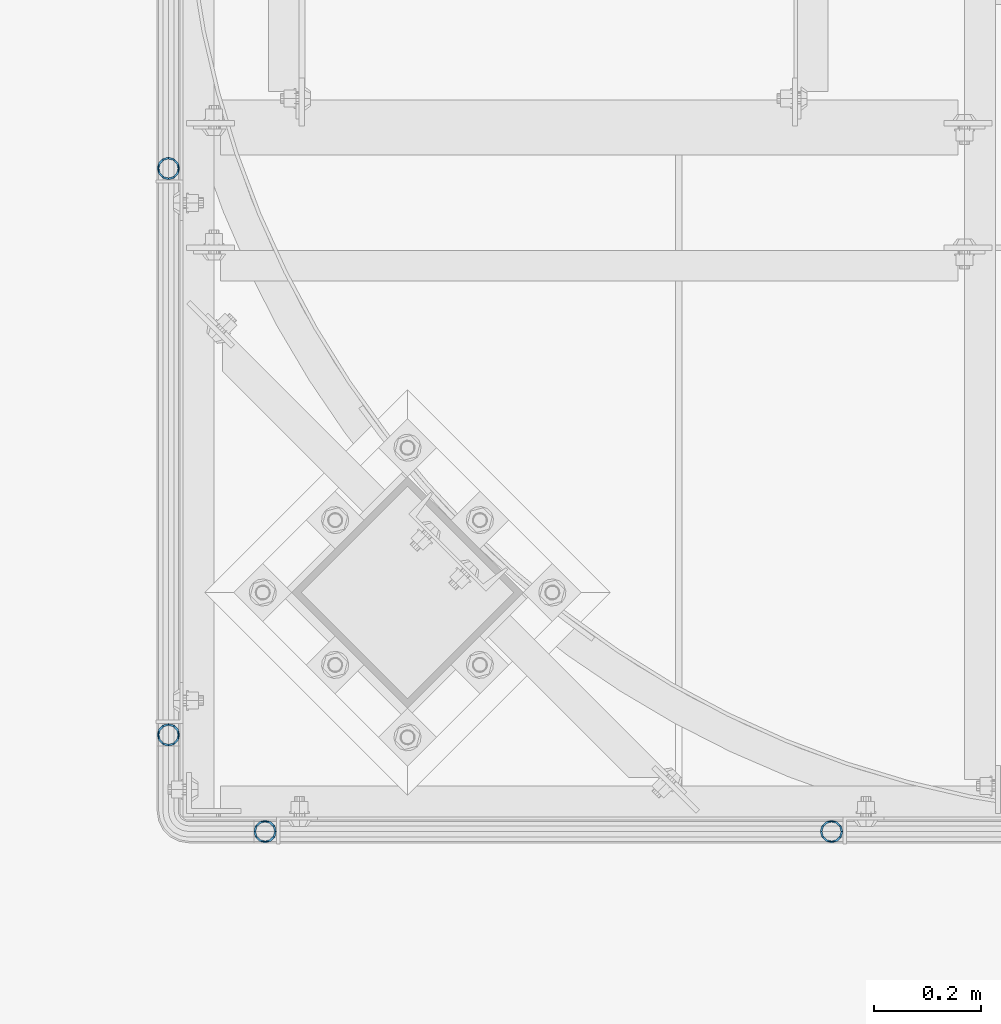
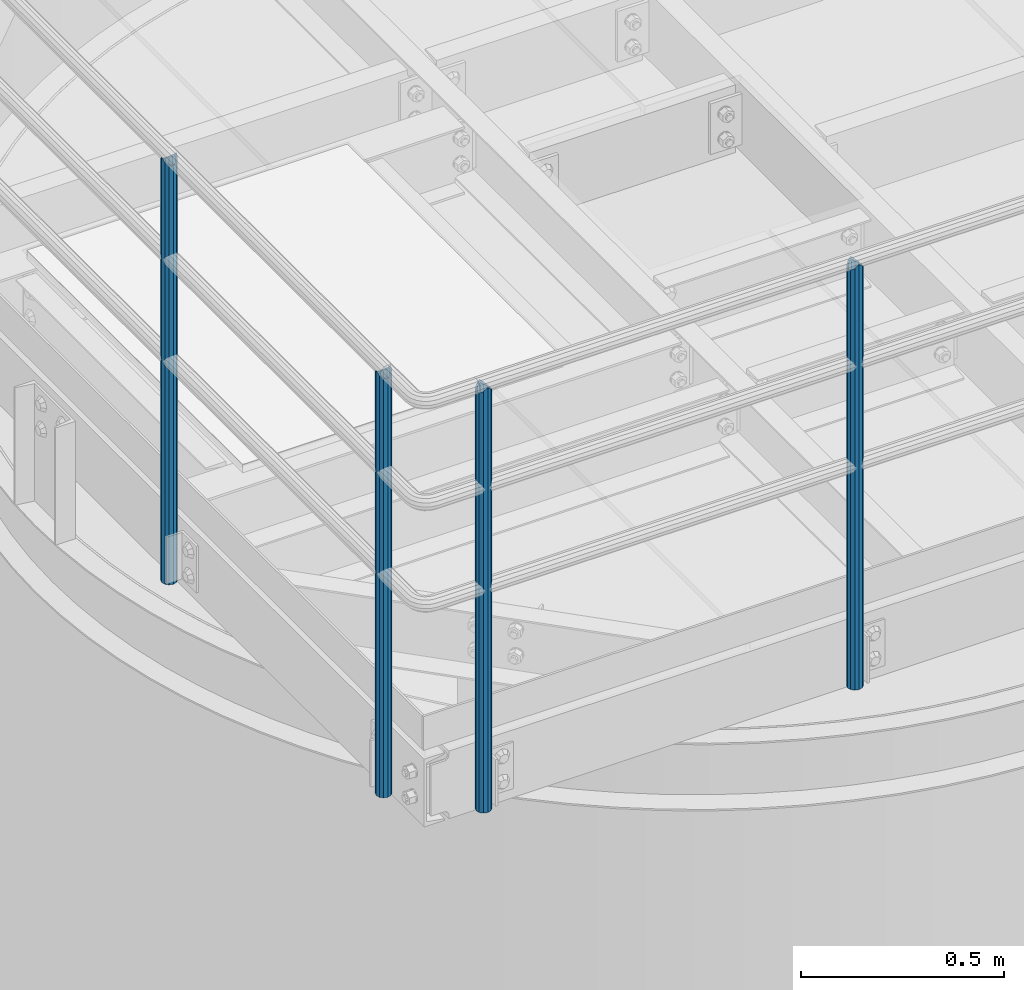
# One storey, part 541 of 1876: 4 columns, 2 elements without a shape of their own.
"""IFC2X3 building model written with IfcOpenShell, lengths in millimetres."""

from ifc_helpers import new_model, si_unit, frame, origin_with_axes, place, context, subcontext, project, spatial, faceted_brep, material, type_object, element, aggregate, save


model = new_model("IFC2X3")

# Units and contexts
model_context = context("Model", 3, precision=1e-05, world=origin_with_axes())
body_context = subcontext(model_context, "Body", "Model", "MODEL_VIEW")
ifc_project = project(units=[si_unit("LENGTHUNIT", "METRE", prefix="MILLI"), si_unit("AREAUNIT", "SQUARE_METRE"), si_unit("VOLUMEUNIT", "CUBIC_METRE"), si_unit("MASSUNIT", "GRAM", prefix="KILO"), si_unit("TIMEUNIT", "SECOND"), si_unit("PLANEANGLEUNIT", "RADIAN"), si_unit("SOLIDANGLEUNIT", "STERADIAN"), si_unit("THERMODYNAMICTEMPERATUREUNIT", "DEGREE_CELSIUS"), si_unit("LUMINOUSINTENSITYUNIT", "LUMEN")], contexts=[model_context])

# Site, building, storey
site_placement = place(None, origin_with_axes())
site = spatial("IfcSite", under=ifc_project, at=site_placement, CompositionType="ELEMENT")
building_placement = place(site_placement, origin_with_axes())
building = spatial("IfcBuilding", under=site, at=building_placement, Name="Undefined", CompositionType="ELEMENT")
storey_placement = place(building_placement, origin_with_axes())
storey = spatial("IfcBuildingStorey", under=building, at=storey_placement, Name="Undefined", CompositionType="ELEMENT", Elevation=0.0)

# Assembly, columns
assembly_1_placement = place(storey_placement, origin_with_axes())
assembly_1 = element("IfcElementAssembly", 1, at=assembly_1_placement, inside=storey, Name="HANDRAIL", AssemblyPlace="NOTDEFINED", PredefinedType="RIGID_FRAME")
ifc_material = material()
column_type = type_object("IfcColumnType", Name="PIPE1-1/4STD", PredefinedType="NOTDEFINED")
column_1_placement = place(assembly_1_placement, frame((4572.00143150122, -15432.4964042969, 7813.675), z_axis=(0.0, 1.0, 0.0), x_axis=(0.0, 0.0, 1.0)))
column_1 = element("IfcColumn", 2, at=column_1_placement, type_object=column_type, material=ifc_material, Name="POST", ObjectType="PIPE1-1/4STD", context=body_context, shape_type="Brep", body=[
    faceted_brep([(1276.35, 0.0, -21.0820000000003), (1265.809, 10.5410000000002, -18.2575475625836), (1265.809, -10.5410000000002, -18.2575475625836), (1257.61603877328, 15.1779612267264, 8.76299999999992), (1255.268, 17.5259999999998, 0.0), (1255.268, 21.0820000000003, 0.0), (1258.09245243742, 18.2575475625836, 10.5410000000002), (1258.09245243742, 13.3999612267262, 10.5410000000002), (1258.09245243742, 13.3999612267262, -10.5410000000002), (1258.09245243742, 18.2575475625836, -10.5410000000002), (1257.61603877328, 15.1779612267264, -8.76299999999992), (1262.72937633681, 8.76299999999992, -15.1779612267255), (1265.07741511008, 0.0, -17.5259999999998), (1262.72937633681, -8.76299999999992, -15.1779612267255), (1258.09245243741, -13.3999612267244, -10.541000000002), (1258.09245243742, -18.2575475625836, -10.5409999999993), (1257.61602877145, -15.1779612267264, -8.76300000000083), (1255.268, -17.5259999999998, 0.0), (1255.268, -21.0820000000003, 0.0), (1257.61604877511, -15.1779612267264, 8.76300000000083), (1258.09245243741, -13.399961226728, 10.5409999999983), (1258.09245243742, -18.2575475625836, 10.5409999999993), (1276.35, 0.0, 21.0820000000003), (1265.809, -10.5410000000002, 18.2575475625836), (1265.809, 10.5410000000002, 18.2575475625836), (1262.72941366414, -8.76299999999992, 15.1779612267264), (1265.07745243742, 0.0, 17.5259999999998), (1262.72941366414, 8.76299999999992, 15.1779612267264), (0.0, -18.2575475625836, -10.5409999999993), (0.0, -10.5410000000002, -18.2575475625836), (-4.28826751885936e-09, 0.0, -21.0820000000003), (0.0, 10.5410000000002, -18.2575475625836), (0.0, 18.2575475625836, -10.5409999999993), (9.09494701772928e-13, 21.0820000000003, 0.0), (0.0, 18.2575475625836, 10.5409999999993), (0.0, 10.5410000000002, 18.2575475625836), (0.0, 0.0, 21.0820000000003), (0.0, -18.2575475625836, 10.5409999999993), (9.09494701772928e-13, -21.0820000000003, 0.0), (0.0, -10.5410000000002, 18.2575475625836), (0.0, -15.1779612267264, -8.76300000000083), (0.0, -8.76299999999992, -15.1779612267255), (0.0, 0.0, -17.5259999999998), (0.0, 8.76299999999992, -15.1779612267255), (0.0, 15.1779612267264, -8.76300000000083), (0.0, 17.5259999999998, 0.0), (0.0, 15.1779612267264, 8.76300000000083), (0.0, 8.76299999999992, 15.1779612267255), (0.0, 0.0, 17.5259999999998), (0.0, -8.76299999999992, 15.1779612267255), (0.0, -15.1779612267264, 8.76300000000083), (0.0, -17.5259999999998, 0.0)], [[[0, 1, 2]], [[3, 4, 5, 6, 7]], [[8, 9, 5, 4, 10]], [[2, 1, 9, 8, 11, 12, 13, 14, 15]], [[15, 14, 16, 17, 18]], [[18, 17, 19, 20, 21]], [[22, 23, 24]], [[21, 20, 25, 26, 27, 7, 6, 24, 23]], [[28, 29, 2, 15]], [[29, 30, 0, 2]], [[30, 31, 1, 0]], [[31, 32, 9, 1]], [[32, 33, 5, 9]], [[33, 34, 6, 5]], [[34, 35, 24, 6]], [[35, 36, 22, 24]], [[37, 38, 18, 21]], [[39, 37, 21, 23]], [[36, 39, 23, 22]], [[38, 28, 15, 18]], [[37, 39, 36, 35, 34, 33, 32, 31, 30, 29, 28, 38], [40, 41, 42, 43, 44, 45, 46, 47, 48, 49, 50, 51]], [[49, 48, 26, 25]], [[19, 50, 49, 25, 20]], [[51, 50, 19, 17]], [[40, 51, 17, 16]], [[41, 40, 16, 14, 13]], [[42, 41, 13, 12]], [[43, 42, 12, 11]], [[10, 44, 43, 11, 8]], [[45, 44, 10, 4]], [[46, 45, 4, 3]], [[47, 46, 3, 7, 27]], [[48, 47, 27, 26]]]),
])
column_2_placement = place(assembly_1_placement, frame((3517.90143150122, -15432.4964042969, 7813.675), z_axis=(0.0, 1.0, 0.0), x_axis=(0.0, 0.0, 1.0)))
column_2 = element("IfcColumn", 3, at=column_2_placement, type_object=column_type, material=ifc_material, Name="POST", ObjectType="PIPE1-1/4STD", context=body_context, shape_type="Brep", body=[
    faceted_brep([(1276.35, 0.0, -21.0820000000003), (1265.809, 10.5410000000002, -18.2575475625836), (1265.809, -10.5410000000002, -18.2575475625836), (1257.61603877328, 15.1779612267264, 8.76299999999992), (1255.268, 17.5259999999998, 0.0), (1255.268, 21.0820000000003, 0.0), (1258.09245243742, 18.2575475625836, 10.5410000000002), (1258.09245243742, 13.3999612267262, 10.5410000000002), (1258.09245243742, 13.3999612267262, -10.5410000000002), (1258.09245243742, 18.2575475625836, -10.5410000000002), (1257.61603877328, 15.1779612267264, -8.76299999999992), (1262.72937633681, 8.76299999999992, -15.1779612267255), (1265.07741511008, 0.0, -17.5259999999998), (1262.72937633681, -8.76299999999992, -15.1779612267255), (1258.09245243741, -13.3999612267244, -10.541000000002), (1258.09245243742, -18.2575475625836, -10.5409999999993), (1257.61602877145, -15.1779612267264, -8.76300000000083), (1255.268, -17.5259999999998, 0.0), (1255.268, -21.0820000000003, 0.0), (1257.61604877511, -15.1779612267264, 8.76300000000083), (1258.09245243741, -13.399961226728, 10.5409999999983), (1258.09245243742, -18.2575475625836, 10.5409999999993), (1276.35, 0.0, 21.0820000000003), (1265.809, -10.5410000000002, 18.2575475625836), (1265.809, 10.5410000000002, 18.2575475625836), (1262.72941366414, -8.76299999999992, 15.1779612267264), (1265.07745243742, 0.0, 17.5259999999998), (1262.72941366414, 8.76299999999992, 15.1779612267264), (0.0, -18.2575475625836, -10.5409999999993), (0.0, -10.5410000000002, -18.2575475625836), (-4.28826751885936e-09, 0.0, -21.0820000000003), (0.0, 10.5410000000002, -18.2575475625836), (0.0, 18.2575475625836, -10.5409999999993), (9.09494701772928e-13, 21.0820000000003, 0.0), (0.0, 18.2575475625836, 10.5409999999993), (0.0, 10.5410000000002, 18.2575475625836), (0.0, 0.0, 21.0820000000003), (0.0, -18.2575475625836, 10.5409999999993), (9.09494701772928e-13, -21.0820000000003, 0.0), (0.0, -10.5410000000002, 18.2575475625836), (0.0, -15.1779612267264, -8.76300000000083), (0.0, -8.76299999999992, -15.1779612267255), (0.0, 0.0, -17.5259999999998), (0.0, 8.76299999999992, -15.1779612267255), (0.0, 15.1779612267264, -8.76300000000083), (0.0, 17.5259999999998, 0.0), (0.0, 15.1779612267264, 8.76300000000083), (0.0, 8.76299999999992, 15.1779612267255), (0.0, 0.0, 17.5259999999998), (0.0, -8.76299999999992, 15.1779612267255), (0.0, -15.1779612267264, 8.76300000000083), (0.0, -17.5259999999998, 0.0)], [[[0, 1, 2]], [[3, 4, 5, 6, 7]], [[8, 9, 5, 4, 10]], [[2, 1, 9, 8, 11, 12, 13, 14, 15]], [[15, 14, 16, 17, 18]], [[18, 17, 19, 20, 21]], [[22, 23, 24]], [[21, 20, 25, 26, 27, 7, 6, 24, 23]], [[28, 29, 2, 15]], [[29, 30, 0, 2]], [[30, 31, 1, 0]], [[31, 32, 9, 1]], [[32, 33, 5, 9]], [[33, 34, 6, 5]], [[34, 35, 24, 6]], [[35, 36, 22, 24]], [[37, 38, 18, 21]], [[39, 37, 21, 23]], [[36, 39, 23, 22]], [[38, 28, 15, 18]], [[37, 39, 36, 35, 34, 33, 32, 31, 30, 29, 28, 38], [40, 41, 42, 43, 44, 45, 46, 47, 48, 49, 50, 51]], [[49, 48, 26, 25]], [[19, 50, 49, 25, 20]], [[51, 50, 19, 17]], [[40, 51, 17, 16]], [[41, 40, 16, 14, 13]], [[42, 41, 13, 12]], [[43, 42, 12, 11]], [[10, 44, 43, 11, 8]], [[45, 44, 10, 4]], [[46, 45, 4, 3]], [[47, 46, 3, 7, 27]], [[48, 47, 27, 26]]]),
])
aggregate(assembly_1, [column_1, column_2])

assembly_2_placement = place(storey_placement, origin_with_axes())
assembly_2 = element("IfcElementAssembly", 4, at=assembly_2_placement, inside=storey, Name="HANDRAIL", AssemblyPlace="NOTDEFINED", PredefinedType="RIGID_FRAME")
column_3_placement = place(assembly_2_placement, frame((3338.06943150122, -14198.5644042969, 7813.675), z_axis=(0.0, 1.0, 0.0), x_axis=(0.0, 0.0, 1.0)))
column_3 = element("IfcColumn", 5, at=column_3_placement, type_object=column_type, material=ifc_material, Name="POST", ObjectType="PIPE1-1/4STD", context=body_context, shape_type="Brep", body=[
    faceted_brep([(1258.09245243742, -10.5410000000002, 18.2575475625836), (1258.09245243742, -10.5410017746963, 13.3999594520301), (1257.61603823465, -8.76299999999992, 15.1779612267255), (1255.268, 0.0, 17.5259999999998), (1255.268, 0.0, 21.0820000000003), (1257.6160393119, 8.76299999999992, 15.1779612267255), (1258.09245243742, 10.5409982253032, 13.3999630014223), (1258.09245243742, 10.5410000000002, 18.2575475625836), (1276.35, 21.0820000000003, 0.0), (1265.809, 18.2575475625836, 10.5410000000002), (1265.809, 18.2575475625836, -10.5410000000002), (1262.72941482472, 15.1779612267264, 8.76300000000083), (1265.07745243742, 17.5259999999998, 0.0), (1262.72941250358, 15.1779612267264, -8.76300000000083), (1258.09245243742, 10.5410000000002, -13.3999612267253), (1258.09245243742, 10.5410000000002, -18.2575475625836), (1257.61603877328, 8.76299999999992, -15.1779612267255), (1255.268, 0.0, -17.5259999999998), (1255.268, 0.0, -21.0820000000003), (1258.09245243742, -10.5410000000002, -13.3999612267253), (1258.09245243742, -10.5410000000002, -18.2575475625836), (1257.61603877328, -8.76299999999992, -15.1779612267255), (1276.35000278283, -21.0820000000003, 0.0), (1265.809, -18.2575475625836, -10.5410000000002), (1265.809, -18.2575475625836, 10.5410000000002), (1262.72941366414, -15.1779612267264, -8.76300000000083), (1265.07745243742, -17.5259999999998, 0.0), (1262.72941366414, -15.1779612267264, 8.76300000000083), (0.0, -18.2575475625836, -10.5409999999993), (0.0, -10.5410000000002, -18.2575475625836), (-4.28826751885936e-09, 0.0, -21.0820000000003), (0.0, 10.5410000000002, -18.2575475625836), (0.0, 18.2575475625836, -10.5409999999993), (9.09494701772928e-13, 21.0820000000003, 0.0), (0.0, 18.2575475625836, 10.5409999999993), (0.0, 10.5410000000002, 18.2575475625836), (0.0, 0.0, 21.0820000000003), (0.0, -10.5410000000002, 18.2575475625836), (0.0, -18.2575475625836, 10.5409999999993), (9.09494701772928e-13, -21.0820000000003, 0.0), (0.0, -15.1779612267264, -8.76300000000083), (0.0, -8.76299999999992, -15.1779612267255), (0.0, 0.0, -17.5259999999998), (0.0, 8.76299999999992, -15.1779612267255), (0.0, 15.1779612267264, -8.76300000000083), (0.0, 17.5259999999998, 0.0), (0.0, 15.1779612267264, 8.76300000000083), (0.0, 8.76299999999992, 15.1779612267255), (0.0, 0.0, 17.5259999999998), (0.0, -8.76299999999992, 15.1779612267255), (0.0, -15.1779612267264, 8.76300000000083), (0.0, -17.5259999999998, 0.0)], [[[0, 1, 2, 3, 4]], [[4, 3, 5, 6, 7]], [[8, 9, 10]], [[7, 6, 11, 12, 13, 14, 15, 10, 9]], [[16, 17, 18, 15, 14]], [[19, 20, 18, 17, 21]], [[22, 23, 24]], [[24, 23, 20, 19, 25, 26, 27, 1, 0]], [[28, 29, 20, 23]], [[29, 30, 18, 20]], [[30, 31, 15, 18]], [[31, 32, 10, 15]], [[32, 33, 8, 10]], [[33, 34, 9, 8]], [[34, 35, 7, 9]], [[35, 36, 4, 7]], [[36, 37, 0, 4]], [[37, 38, 24, 0]], [[38, 39, 22, 24]], [[39, 28, 23, 22]], [[38, 37, 36, 35, 34, 33, 32, 31, 30, 29, 28, 39], [40, 41, 42, 43, 44, 45, 46, 47, 48, 49, 50, 51]], [[40, 51, 26, 25]], [[21, 41, 40, 25, 19]], [[42, 41, 21, 17]], [[43, 42, 17, 16]], [[44, 43, 16, 14, 13]], [[45, 44, 13, 12]], [[46, 45, 12, 11]], [[5, 47, 46, 11, 6]], [[48, 47, 5, 3]], [[49, 48, 3, 2]], [[50, 49, 2, 1, 27]], [[51, 50, 27, 26]]]),
])
column_4_placement = place(assembly_2_placement, frame((3338.06943150122, -15252.6644042969, 7813.675), z_axis=(0.0, 1.0, 0.0), x_axis=(0.0, 0.0, 1.0)))
column_4 = element("IfcColumn", 6, at=column_4_placement, type_object=column_type, material=ifc_material, Name="POST", ObjectType="PIPE1-1/4STD", context=body_context, shape_type="Brep", body=[
    faceted_brep([(1258.09245243742, -10.5410000000002, 18.2575475625836), (1258.09245243742, -10.5410017746963, 13.3999594520301), (1257.61603823465, -8.76299999999992, 15.1779612267255), (1255.268, 0.0, 17.5259999999998), (1255.268, 0.0, 21.0820000000003), (1257.6160393119, 8.76299999999992, 15.1779612267255), (1258.09245243742, 10.5409982253032, 13.3999630014223), (1258.09245243742, 10.5410000000002, 18.2575475625836), (1276.35, 21.0820000000003, 0.0), (1265.809, 18.2575475625836, 10.5410000000002), (1265.809, 18.2575475625836, -10.5410000000002), (1262.72941482472, 15.1779612267264, 8.76300000000083), (1265.07745243742, 17.5259999999998, 0.0), (1262.72941250358, 15.1779612267264, -8.76300000000083), (1258.09245243742, 10.5410000000002, -13.3999612267253), (1258.09245243742, 10.5410000000002, -18.2575475625836), (1257.61603877328, 8.76299999999992, -15.1779612267255), (1255.268, 0.0, -17.5259999999998), (1255.268, 0.0, -21.0820000000003), (1258.09245243742, -10.5410000000002, -13.3999612267253), (1258.09245243742, -10.5410000000002, -18.2575475625836), (1257.61603877328, -8.76299999999992, -15.1779612267255), (1276.35000278283, -21.0820000000003, 0.0), (1265.809, -18.2575475625836, -10.5410000000002), (1265.809, -18.2575475625836, 10.5410000000002), (1262.72941366414, -15.1779612267264, -8.76300000000083), (1265.07745243742, -17.5259999999998, 0.0), (1262.72941366414, -15.1779612267264, 8.76300000000083), (0.0, -18.2575475625836, -10.5409999999993), (0.0, -10.5410000000002, -18.2575475625836), (-4.28826751885936e-09, 0.0, -21.0820000000003), (0.0, 10.5410000000002, -18.2575475625836), (0.0, 18.2575475625836, -10.5409999999993), (9.09494701772928e-13, 21.0820000000003, 0.0), (0.0, 18.2575475625836, 10.5409999999993), (0.0, 10.5410000000002, 18.2575475625836), (0.0, 0.0, 21.0820000000003), (0.0, -10.5410000000002, 18.2575475625836), (0.0, -18.2575475625836, 10.5409999999993), (9.09494701772928e-13, -21.0820000000003, 0.0), (0.0, -15.1779612267264, -8.76300000000083), (0.0, -8.76299999999992, -15.1779612267255), (0.0, 0.0, -17.5259999999998), (0.0, 8.76299999999992, -15.1779612267255), (0.0, 15.1779612267264, -8.76300000000083), (0.0, 17.5259999999998, 0.0), (0.0, 15.1779612267264, 8.76300000000083), (0.0, 8.76299999999992, 15.1779612267255), (0.0, 0.0, 17.5259999999998), (0.0, -8.76299999999992, 15.1779612267255), (0.0, -15.1779612267264, 8.76300000000083), (0.0, -17.5259999999998, 0.0)], [[[0, 1, 2, 3, 4]], [[4, 3, 5, 6, 7]], [[8, 9, 10]], [[7, 6, 11, 12, 13, 14, 15, 10, 9]], [[16, 17, 18, 15, 14]], [[19, 20, 18, 17, 21]], [[22, 23, 24]], [[24, 23, 20, 19, 25, 26, 27, 1, 0]], [[28, 29, 20, 23]], [[29, 30, 18, 20]], [[30, 31, 15, 18]], [[31, 32, 10, 15]], [[32, 33, 8, 10]], [[33, 34, 9, 8]], [[34, 35, 7, 9]], [[35, 36, 4, 7]], [[36, 37, 0, 4]], [[37, 38, 24, 0]], [[38, 39, 22, 24]], [[39, 28, 23, 22]], [[38, 37, 36, 35, 34, 33, 32, 31, 30, 29, 28, 39], [40, 41, 42, 43, 44, 45, 46, 47, 48, 49, 50, 51]], [[40, 51, 26, 25]], [[21, 41, 40, 25, 19]], [[42, 41, 21, 17]], [[43, 42, 17, 16]], [[44, 43, 16, 14, 13]], [[45, 44, 13, 12]], [[46, 45, 12, 11]], [[5, 47, 46, 11, 6]], [[48, 47, 5, 3]], [[49, 48, 3, 2]], [[50, 49, 2, 1, 27]], [[51, 50, 27, 26]]]),
])
aggregate(assembly_2, [column_3, column_4])

save(model, "model.ifc")
